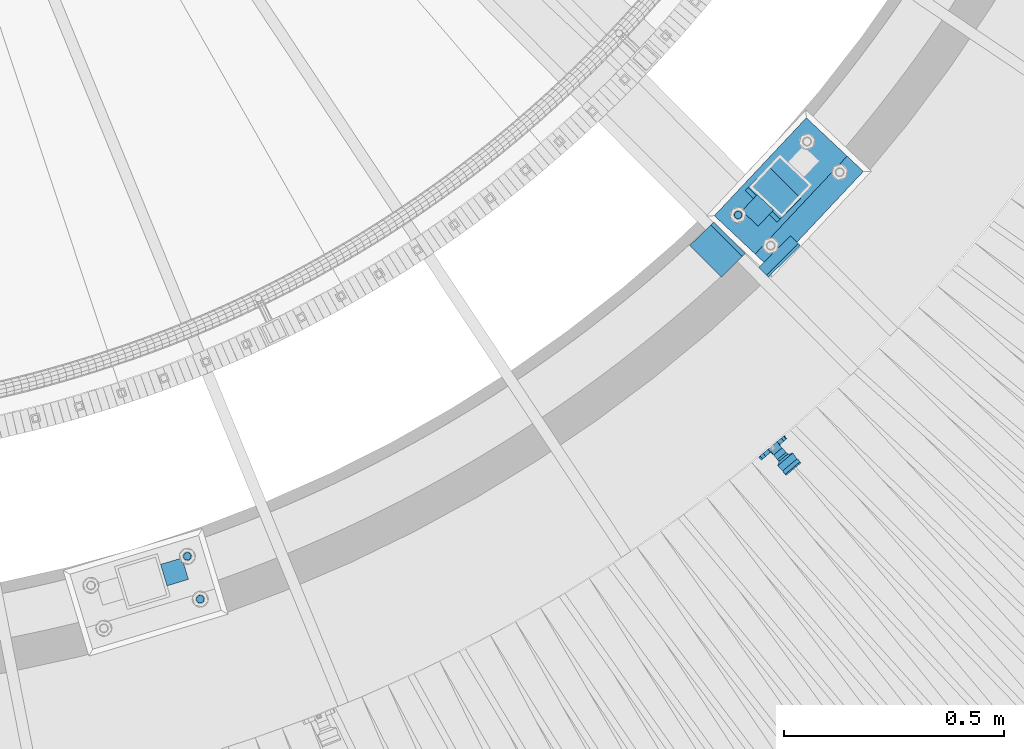
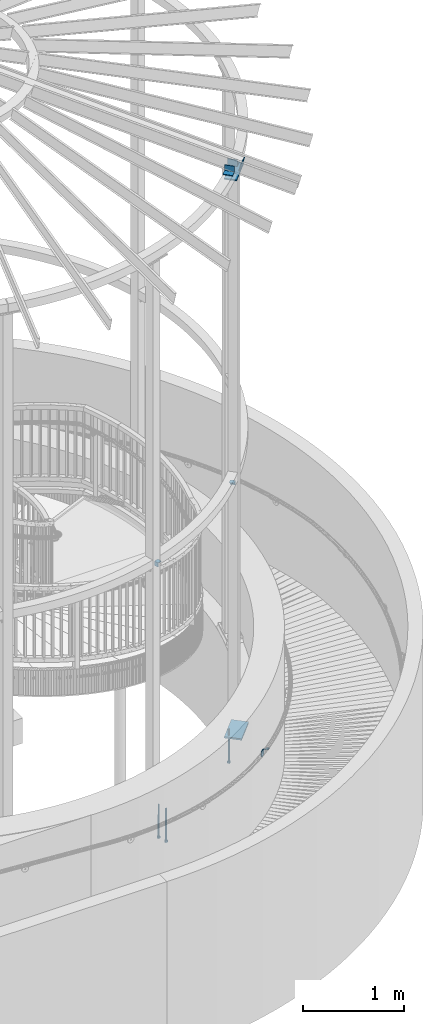
# One storey, part 490 of 975: 10 beams, 1 member.
"""IFC2X3 building model written with IfcOpenShell, lengths in millimetres."""

from ifc_helpers import new_model, si_unit, frame, origin_with_axes, place, context, subcontext, project, spatial, faceted_brep, material, type_object, element, save


model = new_model("IFC2X3")

# Units and contexts
model_context = context("Model", 3, precision=1e-05, world=origin_with_axes())
body_context = subcontext(model_context, "Body", "Model", "MODEL_VIEW")
ifc_project = project(units=[si_unit("LENGTHUNIT", "METRE", prefix="MILLI"), si_unit("AREAUNIT", "SQUARE_METRE"), si_unit("VOLUMEUNIT", "CUBIC_METRE"), si_unit("MASSUNIT", "GRAM", prefix="KILO"), si_unit("TIMEUNIT", "SECOND"), si_unit("PLANEANGLEUNIT", "RADIAN"), si_unit("SOLIDANGLEUNIT", "STERADIAN"), si_unit("THERMODYNAMICTEMPERATUREUNIT", "DEGREE_CELSIUS"), si_unit("LUMINOUSINTENSITYUNIT", "LUMEN")], contexts=[model_context])

# Site, building, storey
site_placement = place(None, origin_with_axes())
site = spatial("IfcSite", under=ifc_project, at=site_placement, CompositionType="ELEMENT")
building_placement = place(site_placement, origin_with_axes())
building = spatial("IfcBuilding", under=site, at=building_placement, Name="Undefined", CompositionType="ELEMENT")
storey_placement = place(building_placement, origin_with_axes())
storey = spatial("IfcBuildingStorey", under=building, at=storey_placement, Name="Undefined", CompositionType="ELEMENT", Elevation=0.0)

# Beams
ifc_material_1 = material(Name="STEEL/A36")
beam_type_1 = type_object("IfcBeamType", PredefinedType="NOTDEFINED")
beam_1_placement = place(storey_placement, frame((37119.1136057212, 551.436036233075, 1500.37741241437), z_axis=(0.764149890963467, 0.64063144696945, -0.0752747852494398), x_axis=(-0.642452624115259, 0.766325404137349, 2.7224000011282e-05)))
element("IfcBeam", 1, at=beam_1_placement, inside=storey, type_object=beam_type_1, material=ifc_material_1, Name="WALL BRACKET", context=body_context, shape_type="Brep", body=[
    faceted_brep([(-1.09139364212751e-11, -35.1998101886752, 14.5802387730655), (0.0, -26.940768363208, 26.9407683632162), (1.2732925824821e-11, -14.5802387731151, 35.1998101887366), (0.0, 0.0, 38.0999984741211), (3.27418092638254e-11, 14.5802387730973, 35.1998101888166), (3.45607986673713e-11, 26.9407683631939, 26.9407683633472), (3.27418092638254e-11, 35.1998101886679, 14.5802387732328), (2.36468622460961e-11, 38.0999999999908, 8.73114913702011e-11), (1.45519152283669e-11, 35.1998101886752, -14.5802387730655), (1.81898940354586e-12, 26.9407683632071, -26.9407683632162), (-1.09139364212751e-11, 14.5802387731146, -35.1998101887511), (0.0, 0.0, -38.0999984741211), (-2.91038304567337e-11, -14.5802387730978, -35.1998101888239), (-3.27418092638254e-11, -26.9407683631948, -26.9407683633617), (-3.09228198602796e-11, -35.1998101886688, -14.5802387732401), (-2.36468622460961e-11, -38.0999999999917, -9.45874489843845e-11), (9.52499999999407, 35.4440469783465, 13.3523775149006), (9.52500000001783, 38.099999999989, 1.23691279441118e-10), (5.45819490078651, 35.1998101886775, 14.58023877304), (5.15915812204861, 35.4440469814256, 13.3523774994246), (5.15916016817869, 35.4440461871586, -13.3523814925829), (5.45819607316758, 35.1998101886757, -14.5802387731565), (9.52499999563867, 35.4440461839649, -13.352381508641), (9.52499999999338, 33.7468954266617, -16.754679378646), (9.52499999999418, 26.9407683632057, -26.9407683631944), (7.23710514487385, 33.7468954167059, -16.7546793935435), (9.52499999997963, 14.5802387731133, -35.199810188722), (9.52499999996871, 7.73070496506989e-12, -38.1000000000931), (9.52499999996326, -14.5802387730996, -35.1998101888021), (9.52499999995962, -26.9407683631966, -26.9407683633399), (9.5249999999578, -35.1998101886768, -14.5802387731064), (9.52499999997235, -38.0999999999935, -7.27595761418343e-11), (9.52499999988504, -35.1998101886779, 14.5802387731401), (9.52499999999418, -26.9407683632098, 26.940768363238), (9.52500000000691, -14.5802387731169, 35.1998101887584), (9.52500000001783, -1.13686837721616e-11, 38.1000000001295), (9.5250000000251, 14.580238773096, 35.1998101888312), (9.52500000002692, 26.9407683631925, 26.9407683633617), (7.23710629084189, 33.7468933804012, 16.7546824409801), (9.52500001802099, 33.74689339, 16.7546824266137), (4.12737783423069, 36.2867482851609, 11.6630037101459), (9.52500001480979, 36.2867482910076, 11.6630037099276), (1.9072828969438, 38.0999998001848, -4.3824766180478e-06), (9.43529109937867, 38.0999998083389, -4.38277129433118e-06), (4.12738199474541, 36.2867456530334, -11.6630120660157), (9.52499999713365, 36.2867456588801, -11.6630120662267), (9.52499998931302, 31.8782691818908, -20.5007361535354), (1.90728516843444, 38.0999984362613, -14.9620414784949), (9.43529504267332, 38.0999984471014, -14.9620414798228), (9.52499998867484, 31.8782692100656, -21.3428983101403), (-0.974480980704527, 40.4536660864392, -13.6176374922397), (6.55352889353486, 40.4536660972792, -13.617637493564), (-3.23293929398841, 48.4467136552532, -12.2071016444133), (-3.86099316375032, 48.9596734302611, -12.3332393299024), (-3.86099415506237, 48.9596734359397, 12.1506042690053), (-3.23294234398753, 48.4467162038179, 12.0244673261113), (6.55352388489973, 40.4536689343606, 13.4350048968336), (9.4352891744017, 38.1000015670843, 14.7794093900302), (-8.88876894391092, 51.462646060533, -12.9487245784876), (-14.5044020842531, 51.5524567377918, -12.9708091785214), (-14.5044031272276, 51.5524567437842, 12.788173508583), (-8.88876998507754, 51.4626460665079, 12.7660889411018), (-16.4483770195459, 51.1442726592504, -12.8704360163174), (-16.4483780543928, 51.1442726651987, 12.6878004343525), (-22.5793182144077, 51.3711360271759, -12.9262221073186), (-22.5793192537777, 51.3711360331463, 12.7435864607032), (-27.8885284154861, 54.4455780358899, -13.6822326528272), (-27.8885295160832, 54.4455780422152, 13.4995963000001), (-28.6196515649072, 55.6169452716154, -13.9702738582564), (-31.1370083013608, 59.6501226213948, -17.5950925222933), (-31.1370097188383, 59.6501226295447, 17.4124524185645), (-28.6196545294583, 55.616948227025, 13.7876379643458), (-33.6296792490059, 67.324805151891, -22.2250062266612), (-32.8101722890036, 64.8016260361878, -22.2250061928717), (-39.3161821982224, 64.9509398614337, -22.2250064563596), (-33.6296810489844, 67.3248051619378, 22.2249937734341), (-39.3127719838823, 64.95236112884, 22.2249935438595), (-32.8101756191698, 64.8016307577993, 22.2249938072164), (-49.8281982508399, 63.7590297560901, -21.2879733583577), (-49.8281999673757, 63.7590297658239, 21.1053316176076), (-62.537662592724, 64.8016282183019, -22.2250073966388), (-62.5376643923654, 64.8016282284259, 22.2249926034456), (-59.3629825026719, 68.3509998487543, 22.2249927311568), (-59.3629807030303, 68.3509998386305, -22.2250072689349), (-56.0005505059879, 61.6533412669896, 22.2249928688907), (-56.0009816237271, 61.6535489521873, 19.2130312653135), (-56.0009816302269, 64.8016307505561, 22.0423689734525), (-51.9930603186979, 64.8016307660225, 22.2249930304133), (-51.9930486616773, 64.8016260085653, -22.2250069696784), (-56.000981616694, 61.6535497473442, -22.2250071312228), (-56.0009816212363, 64.8016260027941, -22.2250068759422), (-56.0009816161877, 61.6535496925769, -19.3956728877092), (-50.6240356350016, 59.0640018412871, -17.0683164176735), (-50.6240370098228, 59.0640018490833, 16.8856764812081), (-37.4851004069614, 60.555058921409, -18.4084041452843), (-37.4851018904596, 60.555058929803, 18.2257636742615), (-36.5628425975134, 60.9400579463424, -18.7544220673662), (-36.5628441090176, 60.9400579547794, 18.5717814508498), (-35.6661101826384, 58.1791091500552, -16.2730189810172), (-35.6661114930633, 58.1791091575863, 16.0903794298065), (-34.0669073739811, 55.616948225869, 13.7876379531408), (-34.0669044052501, 55.6169452637716, -13.9702738572996), (-31.199578137138, 51.0230652214489, -12.8406309028251), (-31.1995791695818, 51.0230652273826, 12.6579953160217), (-13.5258453474495, 46.8920843628518, -12.4814476045976), (-10.0158535806146, 46.8359491542703, -12.491353805628), (-10.0158545847443, 46.8359491600327, 12.308720278641), (-13.5258463507973, 46.8920843686235, 12.298814059428), (-15.4698202757649, 46.4839002842855, -12.5534799881534), (-15.469821284944, 46.4839002900824, 12.3708465294185), (-23.8996230795056, 46.7958284847284, -12.4984339079674), (-23.8996240842331, 46.7958284904998, 12.3158003666576), (-26.7505131823156, 48.4467136213889, -12.207101640266), (-26.7505186046602, 48.4467161988273, 12.0244672777189), (-6.87329577845111, 45.2714927334573, -12.7674339683217), (-6.87329680492121, 45.2714927393397, 12.584800790275), (-0.974485553301008, 40.4536689327629, 13.4350048813394), (1.90728014135857, 38.100001565487, 14.7794093745397), (9.52500002100476, 31.8782677827221, 21.320715892205), (9.52500002038346, 31.878267810155, 20.5007393728483)], [[[0, 1, 2, 3, 4, 5, 6, 7, 8, 9, 10, 11, 12, 13, 14, 15]], [[16, 17, 7, 6, 18, 19]], [[20, 21, 8, 7, 17, 22]], [[23, 24, 9, 8, 21, 25]], [[10, 9, 24, 26]], [[11, 10, 26, 27]], [[12, 11, 27, 28]], [[13, 12, 28, 29]], [[14, 13, 29, 30]], [[15, 14, 30, 31]], [[0, 15, 31, 32]], [[1, 0, 32, 33]], [[2, 1, 33, 34]], [[3, 2, 34, 35]], [[4, 3, 35, 36]], [[5, 4, 36, 37]], [[38, 18, 6, 5, 37, 39]], [[39, 37, 36, 35, 34, 33, 32, 31, 30, 29, 28, 27, 26, 24, 23, 22, 17, 16]], [[40, 41, 16, 19]], [[40, 42, 43, 41]], [[42, 44, 45, 43]], [[46, 23, 25]], [[47, 48, 49]], [[48, 47, 50, 51]], [[51, 52, 53, 54, 55, 56, 57, 48]], [[58, 59, 60, 61]], [[59, 62, 63, 60]], [[62, 64, 65, 63]], [[64, 66, 67, 65]], [[66, 68, 69, 70, 71, 67]], [[72, 73, 74]], [[75, 76, 77]], [[74, 76, 75, 72]], [[74, 78, 79, 76]], [[80, 81, 82, 83]], [[84, 85, 86]], [[82, 81, 84, 86, 87]], [[78, 88, 83, 82, 87, 79]], [[89, 80, 83, 88, 90]], [[89, 90, 91]], [[84, 81, 80, 89, 91, 92, 93, 85]], [[92, 94, 95, 93]], [[94, 96, 97, 95]], [[96, 98, 99, 97]], [[70, 77, 76, 79, 87, 86, 85, 93, 95, 97, 99, 100, 71]], [[69, 73, 72, 75, 77, 70]], [[68, 101, 98, 96, 94, 92, 91, 90, 88, 78, 74, 73, 69]], [[99, 98, 101, 102, 103, 100]], [[104, 105, 106, 107]], [[108, 104, 107, 109]], [[110, 108, 109, 111]], [[103, 102, 112, 110, 111, 113]], [[54, 61, 60, 63, 65, 67, 71, 100, 103, 113, 55]], [[53, 58, 61, 54]], [[52, 112, 102, 101, 68, 66, 64, 62, 59, 58, 53]], [[51, 50, 114, 105, 104, 108, 110, 112, 52]], [[105, 114, 115, 106]], [[55, 113, 111, 109, 107, 106, 115, 116, 56]], [[56, 116, 117, 57]], [[117, 118, 57]], [[39, 16, 41, 43, 45, 22, 23, 46, 49, 48, 57, 118, 119]], [[119, 38, 39]], [[119, 118, 117, 116, 115, 114, 50, 47, 49, 46, 25, 21, 20, 44, 42, 40, 19, 18, 38]], [[45, 44, 20, 22]]]),
])
beam_type_2 = type_object("IfcBeamType", Name="L2X2X1/4", PredefinedType="NOTDEFINED")
for number, where, z_axis, x_axis, name in (
    (2, (35765.8647017349, 249.204050254484, 4445.0), (0.957369928409554, 0.288864709123642, 0.0), (-0.288864709123643, 0.957369928409553, 0.0), "ANGLE"),
    (3, (37063.4904835625, 1111.22423876262, 4445.0), (-0.684674324933948, -0.728849139929686, 0.0), (0.728849139929688, -0.684674324933946, 0.0), "ANGLE"),
):
    element("IfcBeam", number, at=place(storey_placement, frame(where, z_axis=z_axis, x_axis=x_axis)), inside=storey, type_object=beam_type_2, material=ifc_material_1, Name=name, ObjectType="L2X2X1/4", context=body_context, shape_type="Brep", body=[
        faceted_brep([(0.0, 25.3999999999724, -25.4000000000342), (0.0, 25.400000000016, 25.4000000000196), (50.8000000000102, 25.3999999999996, 25.4000000000015), (50.7999999999411, 25.3999999999996, -25.4000000000487), (3.27418092638254e-11, 19.0500000000002, 25.4000000000269), (50.8000000000102, 19.0500000000002, 25.4000000000015), (-2.5465851649642e-11, 19.0500000000002, -19.0500000000211), (50.7999999999483, 19.0500000000002, -19.0500000000429), (-2.5465851649642e-11, -25.3999999999996, -19.0500000000211), (50.7999999999483, -25.3999999999996, -19.0500000000429), (0.0, -25.400000000016, -25.4000000000196), (50.7999999999411, -25.3999999999996, -25.4000000000487)], [[[0, 1, 2, 3]], [[1, 4, 5, 2]], [[4, 6, 7, 5]], [[6, 8, 9, 7]], [[8, 10, 11, 9]], [[10, 0, 3, 11]], [[5, 7, 9, 11, 3, 2]], [[10, 8, 6, 4, 1, 0]]]),
    ])
beam_type_3 = type_object("IfcBeamType", Name="L3X3X3/8", PredefinedType="NOTDEFINED")
for number, where, z_axis, x_axis, name in (
    (4, (37080.9912029778, 1165.84571627682, 8318.5), (0.709692888126235, 0.704511181276098, 5.71968485019169e-10), (0.704511181200146, -0.709692888201633, 9.99996585983236e-10), "ANGLE"),
    (5, (37026.6158613942, 968.706856830136, 8318.5), (-0.709692888126233, -0.7045111812761, 5.71955752093346e-10), (-0.704511181200153, 0.709692888201625, 9.99996585988633e-10), "ANGLE"),
):
    element("IfcBeam", number, at=place(storey_placement, frame(where, z_axis=z_axis, x_axis=x_axis)), inside=storey, type_object=beam_type_3, material=ifc_material_1, Name=name, ObjectType="L3X3X3/8", context=body_context, shape_type="Brep", body=[
        faceted_brep([(-6.18456397205591e-11, 38.0999999999876, -38.1000000000258), (1.45519152283669e-10, 38.1000000000295, 38.1000000000386), (101.599999999788, 38.1000000000004, 38.0999999999767), (101.599999999762, 38.1000000000004, -38.1000000000313), (4.72937244921923e-11, 28.5749999999316, 38.1), (101.599999999788, 28.5750000000007, 38.0999999999767), (4.72937244921923e-11, 28.5749999999316, -28.575), (101.599999999766, 28.5750000000007, -28.5750000000298), (-5.0931703299284e-11, -38.0999999999112, -28.575), (101.599999999766, -38.1000000000004, -28.5750000000298), (-1.41881173476577e-10, -38.1000000000258, -38.1000000000386), (101.599999999762, -38.1000000000004, -38.1000000000313)], [[[0, 1, 2, 3]], [[1, 4, 5, 2]], [[4, 6, 7, 5]], [[6, 8, 9, 7]], [[8, 10, 11, 9]], [[10, 0, 3, 11]], [[5, 7, 9, 11, 3, 2]], [[10, 8, 6, 4, 1, 0]]]),
    ])

# Member
member_type = type_object("IfcMemberType", PredefinedType="NOTDEFINED")
member_placement = place(storey_placement, frame((37122.5709450168, 997.96469796727, 8306.81398391972), z_axis=(0.709692888126235, 0.704511181276098, 5.71968485019169e-10), x_axis=(0.170873527176511, -0.172130267177808, 0.970140922150774)))
element("IfcMember", 6, at=member_placement, inside=storey, type_object=member_type, material=ifc_material_1, Name="PLATE", context=body_context, shape_type="Brep", body=[
    faceted_brep([(0.0, 3.17499999999927, -50.7999999999993), (0.0, 3.17499999999109, 50.7999992370678), (101.600000000738, 3.17500000004657, 50.7999999999374), (101.600000000827, 3.17500000007567, -50.800000000112), (0.0, -3.17500000000882, 50.7999992370605), (101.60000000074, -3.17499999995562, 50.7999999999411), (0.0, -3.17499999999927, -50.7999999999993), (101.60000000083, -3.17499999993379, -50.8000000001084)], [[[0, 1, 2, 3]], [[1, 4, 5, 2]], [[4, 6, 7, 5]], [[6, 0, 3, 7]], [[5, 7, 3, 2]], [[6, 4, 1, 0]]]),
])

# Beams
beam_type_4 = type_object("IfcBeamType", PredefinedType="NOTDEFINED")
beam_2_placement = place(storey_placement, frame((37238.5198023963, 1260.44842429669, 8170.8625), z_axis=(-0.728849139929688, 0.684674324933946, 0.0), x_axis=(-0.684674324933948, -0.728849139929686, 0.0)))
element("IfcBeam", 7, at=beam_2_placement, inside=storey, type_object=beam_type_4, material=ifc_material_1, Name="PLATE", context=body_context, shape_type="Brep", body=[
    faceted_brep([(0.0, 7.9375, -63.5), (0.0, 7.9375, 63.5), (304.799999999529, 7.9375, 63.5), (304.799999999529, 7.9375, -63.5), (0.0, -7.9375, 63.5), (304.799999999529, -7.9375, 63.5), (0.0, -7.9375, -63.5), (304.799999999529, -7.9375, -63.5)], [[[0, 1, 2, 3]], [[1, 4, 5, 2]], [[4, 6, 7, 5]], [[6, 0, 3, 7]], [[5, 7, 3, 2]], [[6, 4, 1, 0]]]),
])
ifc_material_2 = material(Name="STEEL/F1554-36")
beam_type_5 = type_object("IfcBeamType", PredefinedType="NOTDEFINED")
beam_3_placement = place(storey_placement, frame((35787.6661629576, 308.844186243092, 1371.6), z_axis=(-0.957369928409554, -0.288864709123642, 0.0), x_axis=(0.0, 0.0, -1.0)))
element("IfcBeam", 8, at=beam_3_placement, inside=storey, type_object=beam_type_5, material=ifc_material_2, Name="HEADED_ANCHOR_BOLT", context=body_context, shape_type="Brep", body=[
    faceted_brep([(260.34375, -9.13000011445183, 15.8100004195221), (260.34375, -18.2600002289691, -1.45519152283669e-11), (279.393749999999, -18.2600002289691, -1.45519152283669e-11), (279.393749999999, -9.13000011445183, 15.8100004195221), (260.34375, 9.13000011451732, 15.8100004195403), (279.393749999999, 9.13000011451732, 15.8100004195403), (260.34375, 18.2600002289728, 1.81898940354586e-11), (279.393749999999, 18.2600002289728, 1.81898940354586e-11), (260.34375, 9.13000011445547, -15.8100004195221), (279.393749999999, 9.13000011445547, -15.8100004195221), (260.34375, -9.13000011451732, -15.8100004195367), (279.393749999999, -9.13000011451732, -15.8100004195367), (260.34375, -4.47768005528269, 9.29799844174704), (260.34375, -8.06850066050174, 6.43441456486471), (260.34375, -10.0612557562381, 2.29641597050068), (260.34375, -10.0612557562454, -2.29641597051523), (260.34375, -8.06850066052721, -6.43441456487926), (260.34375, -4.47768005531907, -9.29799844175068), (260.34375, -1.81898940354586e-11, -10.319999694766), (260.34375, 4.47768005528633, -9.2979984417434), (260.34375, 8.06850066050174, -6.43441456486471), (260.34375, 10.0612557562381, -2.29641597050068), (260.34375, 10.0612557562454, 2.29641597051886), (260.34375, 8.06850066052357, 6.4344145648829), (260.34375, 4.47768005532271, 9.29799844175432), (260.34375, 2.18278728425503e-11, 10.3199996947696), (279.393749999999, 2.18278728425503e-11, 10.3199996947696), (279.393749999999, -4.47768005528269, 9.29799844174704), (279.393749999999, -8.06850066050174, 6.43441456486471), (279.393749999999, -10.0612557562381, 2.29641597050068), (279.393749999999, -10.0612557562454, -2.29641597051523), (279.393749999999, -8.06850066052721, -6.43441456487926), (279.393749999999, -4.47768005531907, -9.29799844175068), (279.393749999999, -1.81898940354586e-11, -10.319999694766), (279.393749999999, 4.47768005528633, -9.2979984417434), (279.393749999999, 8.06850066050174, -6.43441456486471), (279.393749999999, 10.0612557562381, -2.29641597050068), (279.393749999999, 10.0612557562454, 2.29641597051886), (279.393749999999, 8.06850066052357, 6.4344145648829), (279.393749999999, 4.47768005532271, 9.29799844175432), (0.0, -6.73519209080223, 6.73519209080186), (0.0, -9.52499999999964, 0.0), (279.400000000001, -9.52499999999782, -3.63797880709171e-12), (279.400000000001, -6.73519209079313, 6.73519209079313), (-9.87109982941227e-13, -1.20792265079217e-13, 9.52499961853027), (279.400000000001, 1.09139364212751e-11, 9.52499999999054), (0.0, 6.73519209080223, 6.73519209080186), (279.400000000001, 6.73519209081132, 6.73519209079677), (0.0, 9.52499999999964, 0.0), (279.400000000001, 9.52500000000146, 3.63797880709171e-12), (0.0, 6.73519209080223, -6.73519209080186), (279.400000000001, 6.73519209079677, -6.73519209079313), (2.95075507493764e-12, -1.20792265079217e-13, -9.52499961853027), (279.400000000001, -1.09139364212751e-11, -9.5249999999869), (-126.99791499542, -6.36396103070001, 6.3639610306418), (-126.99791499542, 1.81898940354586e-11, 8.99999999995271), (-126.99791499542, 6.36396103072184, 6.36396103065272), (-126.99791499542, 9.00000000004366, 1.09139364212751e-11), (-126.99791499542, 6.36396103069637, -6.3639610306418), (-126.99791499542, -1.81898940354586e-11, -8.99999999995271), (-126.99791499542, -6.36396103072184, -6.36396103064908), (-126.99791499542, -9.00000000004002, -7.27595761418343e-12), (0.0149743263646087, 6.36396103067818, -6.36396103067909), (0.0149743263646087, 0.0, -9.0), (0.0149743263646087, -6.36396103067818, -6.36396103067909), (0.0149743263987148, -8.9999995411581, -1.00796984270346e-06), (0.0149743263646087, -6.36396103067818, 6.36396103067909), (0.0149743263646087, 0.0, 9.0), (0.0149743263646087, 6.36396103067818, 6.36396103067909), (0.0149743263987148, 9.0000004588419, -1.00796984270346e-06), (0.0, -6.73519209080223, -6.73519209080186), (279.400000000001, -6.73519209080769, -6.73519209079677)], [[[0, 1, 2, 3]], [[4, 0, 3, 5]], [[6, 4, 5, 7]], [[8, 6, 7, 9]], [[10, 8, 9, 11]], [[0, 4, 6, 8, 10, 1], [12, 13, 14, 15, 16, 17, 18, 19, 20, 21, 22, 23, 24, 25]], [[12, 25, 26, 27]], [[13, 12, 27, 28]], [[14, 13, 28, 29]], [[15, 14, 29, 30]], [[16, 15, 30, 31]], [[17, 16, 31, 32]], [[18, 17, 32, 33]], [[19, 18, 33, 34]], [[20, 19, 34, 35]], [[21, 20, 35, 36]], [[22, 21, 36, 37]], [[23, 22, 37, 38]], [[24, 23, 38, 39]], [[25, 24, 39, 26]], [[9, 7, 5, 3, 2, 11], [38, 37, 36, 35, 34, 33, 32, 31, 30, 29, 28, 27, 26, 39]], [[1, 10, 11, 2]], [[40, 41, 42, 43]], [[44, 40, 43, 45]], [[46, 44, 45, 47]], [[48, 46, 47, 49]], [[50, 48, 49, 51]], [[52, 50, 51, 53]], [[54, 55, 56, 57, 58, 59, 60, 61]], [[59, 58, 62, 63]], [[60, 59, 63, 64]], [[61, 60, 64, 65]], [[54, 61, 65, 66]], [[55, 54, 66, 67]], [[56, 55, 67, 68]], [[57, 56, 68, 69]], [[58, 57, 69, 62]], [[40, 44, 46, 48, 50, 52, 70, 41], [68, 67, 66, 65, 64, 63, 62, 69]], [[41, 70, 71, 42]], [[53, 51, 49, 47, 45, 43, 42, 71]], [[70, 52, 53, 71]]]),
])
beam_4_placement = place(storey_placement, frame((35817.0148232198, 211.575403271053, 1371.6), z_axis=(0.957369928409554, 0.288864709123642, 0.0), x_axis=(0.0, 0.0, -1.0)))
element("IfcBeam", 9, at=beam_4_placement, inside=storey, type_object=beam_type_5, material=ifc_material_2, Name="HEADED_ANCHOR_BOLT", context=body_context, shape_type="Brep", body=[
    faceted_brep([(260.34375, -9.13000011445183, 15.8100004195221), (260.34375, -18.2600002289691, -1.45519152283669e-11), (279.393749999999, -18.2600002289691, -1.45519152283669e-11), (279.393749999999, -9.13000011445183, 15.8100004195221), (260.34375, 9.13000011451732, 15.8100004195403), (279.393749999999, 9.13000011451732, 15.8100004195403), (260.34375, 18.2600002289728, 1.81898940354586e-11), (279.393749999999, 18.2600002289728, 1.81898940354586e-11), (260.34375, 9.13000011445547, -15.8100004195221), (279.393749999999, 9.13000011445547, -15.8100004195221), (260.34375, -9.13000011451732, -15.8100004195367), (279.393749999999, -9.13000011451732, -15.8100004195367), (260.34375, -4.47768005528269, 9.29799844174704), (260.34375, -8.06850066050174, 6.43441456486471), (260.34375, -10.0612557562381, 2.29641597050068), (260.34375, -10.0612557562454, -2.29641597051523), (260.34375, -8.06850066052721, -6.43441456487926), (260.34375, -4.47768005531907, -9.29799844175068), (260.34375, -1.81898940354586e-11, -10.319999694766), (260.34375, 4.47768005528633, -9.2979984417434), (260.34375, 8.06850066050174, -6.43441456486471), (260.34375, 10.0612557562381, -2.29641597050068), (260.34375, 10.0612557562454, 2.29641597051886), (260.34375, 8.06850066052357, 6.4344145648829), (260.34375, 4.47768005532271, 9.29799844175432), (260.34375, 2.18278728425503e-11, 10.3199996947696), (279.393749999999, 2.18278728425503e-11, 10.3199996947696), (279.393749999999, -4.47768005528269, 9.29799844174704), (279.393749999999, -8.06850066050174, 6.43441456486471), (279.393749999999, -10.0612557562381, 2.29641597050068), (279.393749999999, -10.0612557562454, -2.29641597051523), (279.393749999999, -8.06850066052721, -6.43441456487926), (279.393749999999, -4.47768005531907, -9.29799844175068), (279.393749999999, -1.81898940354586e-11, -10.319999694766), (279.393749999999, 4.47768005528633, -9.2979984417434), (279.393749999999, 8.06850066050174, -6.43441456486471), (279.393749999999, 10.0612557562381, -2.29641597050068), (279.393749999999, 10.0612557562454, 2.29641597051886), (279.393749999999, 8.06850066052357, 6.4344145648829), (279.393749999999, 4.47768005532271, 9.29799844175432), (0.0, -6.73519209080223, 6.73519209080186), (0.0, -9.52499999999964, 0.0), (279.400000000001, -9.52499999999782, -3.63797880709171e-12), (279.400000000001, -6.73519209079313, 6.73519209079313), (-9.87109982941227e-13, -1.20792265079217e-13, 9.52499961853027), (279.400000000001, 1.09139364212751e-11, 9.52499999999054), (0.0, 6.73519209080223, 6.73519209080186), (279.400000000001, 6.73519209081132, 6.73519209079677), (0.0, 9.52499999999964, 0.0), (279.400000000001, 9.52500000000146, 3.63797880709171e-12), (0.0, 6.73519209080223, -6.73519209080186), (279.400000000001, 6.73519209079677, -6.73519209079313), (2.95075507493764e-12, -1.20792265079217e-13, -9.52499961853027), (279.400000000001, -1.09139364212751e-11, -9.5249999999869), (-126.99791499542, -6.36396103070001, 6.3639610306418), (-126.99791499542, 1.81898940354586e-11, 8.99999999995271), (-126.99791499542, 6.36396103072184, 6.36396103065272), (-126.99791499542, 9.00000000004366, 1.09139364212751e-11), (-126.99791499542, 6.36396103069637, -6.3639610306418), (-126.99791499542, -1.81898940354586e-11, -8.99999999995271), (-126.99791499542, -6.36396103072184, -6.36396103064908), (-126.99791499542, -9.00000000004002, -7.27595761418343e-12), (0.0149743263646087, 6.36396103067818, -6.36396103067909), (0.0149743263646087, 0.0, -9.0), (0.0149743263646087, -6.36396103067818, -6.36396103067909), (0.0149743263987148, -8.9999995411581, -1.00796984270346e-06), (0.0149743263646087, -6.36396103067818, 6.36396103067909), (0.0149743263646087, 0.0, 9.0), (0.0149743263646087, 6.36396103067818, 6.36396103067909), (0.0149743263987148, 9.0000004588419, -1.00796984270346e-06), (0.0, -6.73519209080223, -6.73519209080186), (279.400000000001, -6.73519209080769, -6.73519209079677)], [[[0, 1, 2, 3]], [[4, 0, 3, 5]], [[6, 4, 5, 7]], [[8, 6, 7, 9]], [[10, 8, 9, 11]], [[0, 4, 6, 8, 10, 1], [12, 13, 14, 15, 16, 17, 18, 19, 20, 21, 22, 23, 24, 25]], [[12, 25, 26, 27]], [[13, 12, 27, 28]], [[14, 13, 28, 29]], [[15, 14, 29, 30]], [[16, 15, 30, 31]], [[17, 16, 31, 32]], [[18, 17, 32, 33]], [[19, 18, 33, 34]], [[20, 19, 34, 35]], [[21, 20, 35, 36]], [[22, 21, 36, 37]], [[23, 22, 37, 38]], [[24, 23, 38, 39]], [[25, 24, 39, 26]], [[9, 7, 5, 3, 2, 11], [38, 37, 36, 35, 34, 33, 32, 31, 30, 29, 28, 27, 26, 39]], [[1, 10, 11, 2]], [[40, 41, 42, 43]], [[44, 40, 43, 45]], [[46, 44, 45, 47]], [[48, 46, 47, 49]], [[50, 48, 49, 51]], [[52, 50, 51, 53]], [[54, 55, 56, 57, 58, 59, 60, 61]], [[59, 58, 62, 63]], [[60, 59, 63, 64]], [[61, 60, 64, 65]], [[54, 61, 65, 66]], [[55, 54, 66, 67]], [[56, 55, 67, 68]], [[57, 56, 68, 69]], [[58, 57, 69, 62]], [[40, 44, 46, 48, 50, 52, 70, 41], [68, 67, 66, 65, 64, 63, 62, 69]], [[41, 70, 71, 42]], [[53, 51, 49, 47, 45, 43, 42, 71]], [[70, 52, 53, 71]]]),
])
beam_5_placement = place(storey_placement, frame((37037.4043876041, 1083.45508208298, 1371.6), z_axis=(-0.684674324933948, -0.728849139929686, 0.0), x_axis=(0.0, 0.0, -1.0)))
element("IfcBeam", 10, at=beam_5_placement, inside=storey, type_object=beam_type_5, material=ifc_material_2, Name="HEADED_ANCHOR_BOLT", context=body_context, shape_type="Brep", body=[
    faceted_brep([(260.34375, -9.13000011445183, 15.8100004195221), (260.34375, -18.2600002289691, -1.45519152283669e-11), (279.393749999999, -18.2600002289691, -1.45519152283669e-11), (279.393749999999, -9.13000011445183, 15.8100004195221), (260.34375, 9.13000011451732, 15.8100004195403), (279.393749999999, 9.13000011451732, 15.8100004195403), (260.34375, 18.2600002289728, 1.81898940354586e-11), (279.393749999999, 18.2600002289728, 1.81898940354586e-11), (260.34375, 9.13000011445547, -15.8100004195221), (279.393749999999, 9.13000011445547, -15.8100004195221), (260.34375, -9.13000011451732, -15.8100004195367), (279.393749999999, -9.13000011451732, -15.8100004195367), (260.34375, -4.47768005528269, 9.29799844174704), (260.34375, -8.06850066050174, 6.43441456486471), (260.34375, -10.0612557562381, 2.29641597050068), (260.34375, -10.0612557562454, -2.29641597051523), (260.34375, -8.06850066052721, -6.43441456487926), (260.34375, -4.47768005531907, -9.29799844175068), (260.34375, -1.81898940354586e-11, -10.319999694766), (260.34375, 4.47768005528633, -9.2979984417434), (260.34375, 8.06850066050174, -6.43441456486471), (260.34375, 10.0612557562381, -2.29641597050068), (260.34375, 10.0612557562454, 2.29641597051886), (260.34375, 8.06850066052357, 6.4344145648829), (260.34375, 4.47768005532271, 9.29799844175432), (260.34375, 2.18278728425503e-11, 10.3199996947696), (279.393749999999, 2.18278728425503e-11, 10.3199996947696), (279.393749999999, -4.47768005528269, 9.29799844174704), (279.393749999999, -8.06850066050174, 6.43441456486471), (279.393749999999, -10.0612557562381, 2.29641597050068), (279.393749999999, -10.0612557562454, -2.29641597051523), (279.393749999999, -8.06850066052721, -6.43441456487926), (279.393749999999, -4.47768005531907, -9.29799844175068), (279.393749999999, -1.81898940354586e-11, -10.319999694766), (279.393749999999, 4.47768005528633, -9.2979984417434), (279.393749999999, 8.06850066050174, -6.43441456486471), (279.393749999999, 10.0612557562381, -2.29641597050068), (279.393749999999, 10.0612557562454, 2.29641597051886), (279.393749999999, 8.06850066052357, 6.4344145648829), (279.393749999999, 4.47768005532271, 9.29799844175432), (0.0, -6.73519209080223, 6.73519209080186), (0.0, -9.52499999999964, 0.0), (279.400000000001, -9.52499999999782, -3.63797880709171e-12), (279.400000000001, -6.73519209079313, 6.73519209079313), (-9.87109982941227e-13, -1.20792265079217e-13, 9.52499961853027), (279.400000000001, 1.09139364212751e-11, 9.52499999999054), (0.0, 6.73519209080223, 6.73519209080186), (279.400000000001, 6.73519209081132, 6.73519209079677), (0.0, 9.52499999999964, 0.0), (279.400000000001, 9.52500000000146, 3.63797880709171e-12), (0.0, 6.73519209080223, -6.73519209080186), (279.400000000001, 6.73519209079677, -6.73519209079313), (2.95075507493764e-12, -1.20792265079217e-13, -9.52499961853027), (279.400000000001, -1.09139364212751e-11, -9.5249999999869), (-126.99791499542, -6.36396103070001, 6.3639610306418), (-126.99791499542, 1.81898940354586e-11, 8.99999999995271), (-126.99791499542, 6.36396103072184, 6.36396103065272), (-126.99791499542, 9.00000000004366, 1.09139364212751e-11), (-126.99791499542, 6.36396103069637, -6.3639610306418), (-126.99791499542, -1.81898940354586e-11, -8.99999999995271), (-126.99791499542, -6.36396103072184, -6.36396103064908), (-126.99791499542, -9.00000000004002, -7.27595761418343e-12), (0.0149743263646087, 6.36396103067818, -6.36396103067909), (0.0149743263646087, 0.0, -9.0), (0.0149743263646087, -6.36396103067818, -6.36396103067909), (0.0149743263987148, -8.9999995411581, -1.00796984270346e-06), (0.0149743263646087, -6.36396103067818, 6.36396103067909), (0.0149743263646087, 0.0, 9.0), (0.0149743263646087, 6.36396103067818, 6.36396103067909), (0.0149743263987148, 9.0000004588419, -1.00796984270346e-06), (0.0, -6.73519209080223, -6.73519209080186), (279.400000000001, -6.73519209080769, -6.73519209079677)], [[[0, 1, 2, 3]], [[4, 0, 3, 5]], [[6, 4, 5, 7]], [[8, 6, 7, 9]], [[10, 8, 9, 11]], [[0, 4, 6, 8, 10, 1], [12, 13, 14, 15, 16, 17, 18, 19, 20, 21, 22, 23, 24, 25]], [[12, 25, 26, 27]], [[13, 12, 27, 28]], [[14, 13, 28, 29]], [[15, 14, 29, 30]], [[16, 15, 30, 31]], [[17, 16, 31, 32]], [[18, 17, 32, 33]], [[19, 18, 33, 34]], [[20, 19, 34, 35]], [[21, 20, 35, 36]], [[22, 21, 36, 37]], [[23, 22, 37, 38]], [[24, 23, 38, 39]], [[25, 24, 39, 26]], [[9, 7, 5, 3, 2, 11], [38, 37, 36, 35, 34, 33, 32, 31, 30, 29, 28, 27, 26, 39]], [[1, 10, 11, 2]], [[40, 41, 42, 43]], [[44, 40, 43, 45]], [[46, 44, 45, 47]], [[48, 46, 47, 49]], [[50, 48, 49, 51]], [[52, 50, 51, 53]], [[54, 55, 56, 57, 58, 59, 60, 61]], [[59, 58, 62, 63]], [[60, 59, 63, 64]], [[61, 60, 64, 65]], [[54, 61, 65, 66]], [[55, 54, 66, 67]], [[56, 55, 67, 68]], [[57, 56, 68, 69]], [[58, 57, 69, 62]], [[40, 44, 46, 48, 50, 52, 70, 41], [68, 67, 66, 65, 64, 63, 62, 69]], [[41, 70, 71, 42]], [[53, 51, 49, 47, 45, 43, 42, 71]], [[70, 52, 53, 71]]]),
])
beam_type_6 = type_object("IfcBeamType", PredefinedType="NOTDEFINED")
beam_6_placement = place(storey_placement, frame((37257.0325705504, 1243.05769644399, 1419.225), z_axis=(0.728849139929688, -0.684674324933946, 0.0), x_axis=(-0.684674324933948, -0.728849139929686, 0.0)))
element("IfcBeam", 11, at=beam_6_placement, inside=storey, type_object=beam_type_6, material=ifc_material_1, Name="PLATE", context=body_context, shape_type="Brep", body=[
    faceted_brep([(0.0, 9.52499999999964, -88.9000000000015), (0.0, 9.52499999999964, 88.9000000000015), (304.800000000429, 9.52500000000009, 88.9000000003653), (304.800000000414, 9.52500000000009, -88.8999999996704), (0.0, -9.52499999999964, 88.9000000000015), (304.800000000429, -9.52500000000009, 88.9000000003653), (0.0, -9.52499999999964, -88.9000000000015), (304.800000000414, -9.52500000000009, -88.8999999996704)], [[[0, 1, 2, 3]], [[1, 4, 5, 2]], [[4, 6, 7, 5]], [[6, 0, 3, 7]], [[5, 7, 3, 2]], [[6, 4, 1, 0]]]),
])

save(model, "model.ifc")
